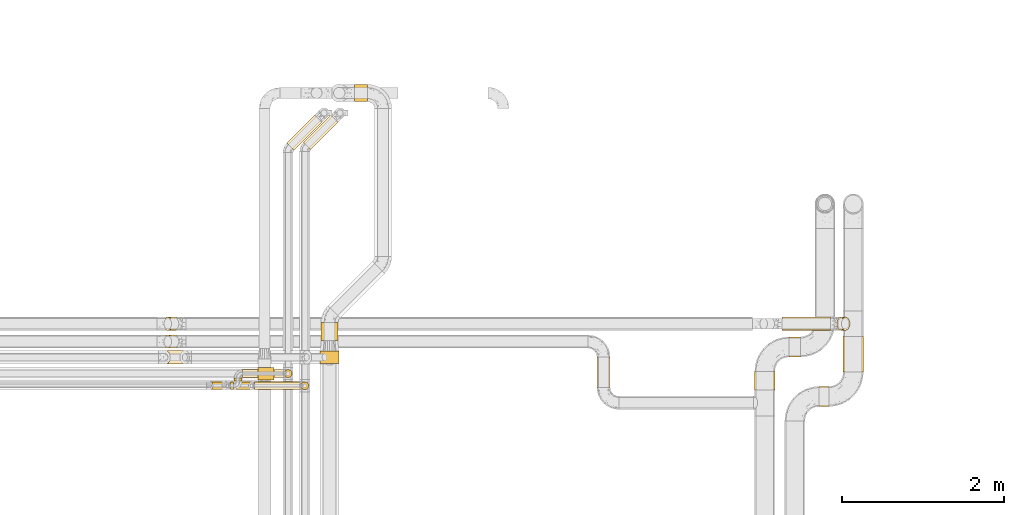
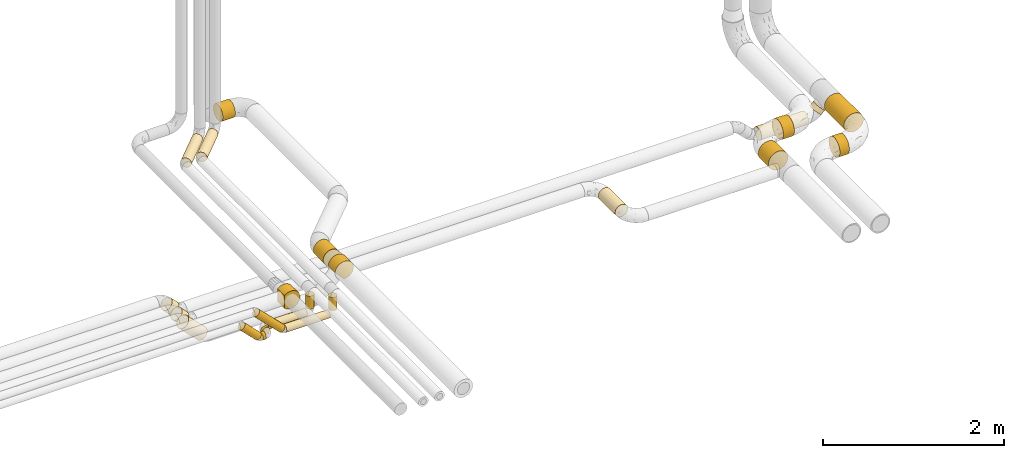
# One storey, part 4 of 93: 24 coverings.
"""IFC2X3 building model written with IfcOpenShell, lengths in millimetres."""

from ifc_helpers import new_model, entity, si_unit, converted_unit, derived_unit, direction, frame, frame_2d, origin, origin_2d_with_axis, place, context, subcontext, project, spatial, polyline, circle_curve, parameter, trimmed, segment, composite_curve, circle, outline, extrude, element, save


model = new_model("IFC2X3")

# Units and contexts
model_context = context("Model", 3, precision=0.01, world=origin(), true_north=direction((6.12303176911189e-17, 1.0)))
body_context = subcontext(model_context, "Body", "Model", "MODEL_VIEW")
ifc_project = project(units=[si_unit("LENGTHUNIT", "METRE", prefix="MILLI"), si_unit("AREAUNIT", "SQUARE_METRE"), si_unit("VOLUMEUNIT", "CUBIC_METRE"), converted_unit("PLANEANGLEUNIT", "DEGREE", entity("IfcRatioMeasure", 0.0174532925199433), si_unit("PLANEANGLEUNIT", "RADIAN"), dimensions=[0, 0, 0, 0, 0, 0, 0]), si_unit("MASSUNIT", "GRAM", prefix="KILO"), derived_unit("MASSDENSITYUNIT", [(si_unit("MASSUNIT", "GRAM", prefix="KILO"), 1), (si_unit("LENGTHUNIT", "METRE"), -3)]), derived_unit("MOMENTOFINERTIAUNIT", [(si_unit("LENGTHUNIT", "METRE"), 4)]), si_unit("TIMEUNIT", "SECOND"), si_unit("FREQUENCYUNIT", "HERTZ"), si_unit("THERMODYNAMICTEMPERATUREUNIT", "DEGREE_CELSIUS"), derived_unit("THERMALTRANSMITTANCEUNIT", [(si_unit("MASSUNIT", "GRAM", prefix="KILO"), 1), (si_unit("THERMODYNAMICTEMPERATUREUNIT", "KELVIN"), -1), (si_unit("TIMEUNIT", "SECOND"), -3)]), derived_unit("VOLUMETRICFLOWRATEUNIT", [(si_unit("LENGTHUNIT", "METRE"), 3), (si_unit("TIMEUNIT", "SECOND"), -1)]), derived_unit("MASSFLOWRATEUNIT", [(si_unit("MASSUNIT", "GRAM", prefix="KILO"), 1), (si_unit("TIMEUNIT", "SECOND"), -1)]), derived_unit("ROTATIONALFREQUENCYUNIT", [(si_unit("TIMEUNIT", "SECOND"), -1)]), si_unit("ELECTRICCURRENTUNIT", "AMPERE"), si_unit("ELECTRICVOLTAGEUNIT", "VOLT"), si_unit("POWERUNIT", "WATT"), si_unit("FORCEUNIT", "NEWTON", prefix="KILO"), si_unit("ILLUMINANCEUNIT", "LUX"), si_unit("LUMINOUSFLUXUNIT", "LUMEN"), si_unit("LUMINOUSINTENSITYUNIT", "CANDELA"), derived_unit("USERDEFINED", [(si_unit("MASSUNIT", "GRAM", prefix="KILO"), -1), (si_unit("LENGTHUNIT", "METRE"), -2), (si_unit("TIMEUNIT", "SECOND"), 3), (si_unit("LUMINOUSFLUXUNIT", "LUMEN"), 1)]), derived_unit("LINEARVELOCITYUNIT", [(si_unit("LENGTHUNIT", "METRE"), 1), (si_unit("TIMEUNIT", "SECOND"), -1)]), si_unit("PRESSUREUNIT", "PASCAL"), derived_unit("USERDEFINED", [(si_unit("LENGTHUNIT", "METRE"), -2), (si_unit("MASSUNIT", "GRAM", prefix="KILO"), 1), (si_unit("TIMEUNIT", "SECOND"), -2)]), derived_unit("LINEARFORCEUNIT", [(si_unit("MASSUNIT", "GRAM", prefix="KILO"), 1), (si_unit("LENGTHUNIT", "METRE"), 1), (si_unit("TIMEUNIT", "SECOND"), -2), (si_unit("LENGTHUNIT", "METRE"), -1)]), derived_unit("PLANARFORCEUNIT", [(si_unit("MASSUNIT", "GRAM", prefix="KILO"), 1), (si_unit("LENGTHUNIT", "METRE"), 1), (si_unit("TIMEUNIT", "SECOND"), -2), (si_unit("LENGTHUNIT", "METRE"), -2)])], contexts=[model_context])

# Site, building, storey
site_placement = place(None, origin())
site = spatial("IfcSite", under=ifc_project, at=site_placement, CompositionType="ELEMENT")
building_placement = place(site_placement, origin())
building = spatial("IfcBuilding", under=site, at=building_placement, CompositionType="ELEMENT")
storey_placement = place(building_placement, frame((0.0, 0.0, -4200.0)))
storey = spatial("IfcBuildingStorey", under=building, at=storey_placement, CompositionType="ELEMENT", Elevation=-4200.0)

# Coverings
covering_1_placement = place(storey_placement, frame((24871.2, 9268.64, 2891.9)))
element("IfcCovering", 1, at=covering_1_placement, inside=storey, Name=":ADSK_", ObjectType=":ADSK_", PredefinedType="INSULATION", context=body_context, shape_type="SweptSolid", body=[
    extrude(circle(Radius=106.5, at=origin_2d_with_axis()), frame((108.1, 0.0, 108.1), z_axis=(0.0, 1.0, 0.0), x_axis=(-1.0, 0.0, 0.0)), (0.0, 0.0, 1.0), 218.399081147116),
])
covering_2_placement = place(storey_placement, frame((25289.12, 12207.47, 2891.9)))
element("IfcCovering", 2, at=covering_2_placement, inside=storey, Name=":ADSK_", ObjectType=":ADSK_", PredefinedType="INSULATION", context=body_context, shape_type="SweptSolid", body=[
    extrude(circle(Radius=106.5, at=origin_2d_with_axis()), frame((0.0, 108.1, 108.1), z_axis=(1.0, 0.0, 0.0), x_axis=(0.0, -1.0, 0.0)), (0.0, 0.0, 1.0), 159.999999999968),
])
covering_3_placement = place(storey_placement, frame((28270.31, 8690.0, 2716.9)))
element("IfcCovering", 3, at=covering_3_placement, inside=storey, Name=":ADSK_", ObjectType=":ADSK_", PredefinedType="INSULATION", context=body_context, shape_type="SweptSolid", body=[
    extrude(circle(Radius=81.5, at=origin_2d_with_axis()), frame((83.1, 0.0, 83.1), z_axis=(0.0, 1.0, 0.0), x_axis=(1.0, 0.0, 0.0)), (0.0, 0.0, 1.0), 374.737441299343),
])
covering_4_placement = place(storey_placement, frame((24451.19, 11608.89, 2935.4)))
element("IfcCovering", 4, at=covering_4_placement, inside=storey, Name=":ADSK_", ObjectType=":ADSK_", PredefinedType="INSULATION", context=body_context, shape_type="SweptSolid", body=[
    extrude(circle(Radius=63.0, at=origin_2d_with_axis()), frame((46.14, 46.14, 64.6), z_axis=(0.707106781186561, 0.707106781186534, 0.0), x_axis=(-0.707106781186534, 0.707106781186561, 0.0)), (0.0, 0.0, 1.0), 486.862915010174),
])
covering_5_placement = place(storey_placement, frame((24417.45, 8810.55, 2757.0)))
element("IfcCovering", 5, at=covering_5_placement, inside=storey, Name=":ADSK_", ObjectType=":ADSK_", PredefinedType="INSULATION", context=body_context, shape_type="SweptSolid", body=[
    extrude(circle(Radius=49.0, at=origin_2d_with_axis()), frame((50.6, 50.6, 0.0)), (0.0, 0.0, 1.0), 176.000000000013),
])
covering_6_placement = place(storey_placement, frame((23756.66, 8660.55, 2649.4)))
element("IfcCovering", 6, at=covering_6_placement, inside=storey, Name=":ADSK_", ObjectType=":ADSK_", PredefinedType="INSULATION", context=body_context, shape_type="SweptSolid", body=[
    extrude(circle(Radius=49.0, at=origin_2d_with_axis()), frame((0.0, 50.6, 50.6), z_axis=(1.0, 0.0, 0.0), x_axis=(0.0, 1.0, 0.0)), (0.0, 0.0, 1.0), 39.389826944728),
])
covering_7_placement = place(storey_placement, frame((23470.65, 8660.55, 2680.45)))
element("IfcCovering", 7, at=covering_7_placement, inside=storey, Name=":ADSK_", ObjectType=":ADSK_", PredefinedType="INSULATION", context=body_context, shape_type="SweptSolid", body=[
    extrude(circle(Radius=49.0, at=origin_2d_with_axis()), frame((245.7, 50.6, 36.24), z_axis=(-0.70710678118655, 0.0, 0.707106781186545), x_axis=(0.0, -1.0, 0.0)), (0.0, 0.0, 1.0), 296.211111394568),
])
covering_8_placement = place(storey_placement, frame((23910.05, 8810.55, 2649.4)))
element("IfcCovering", 8, at=covering_8_placement, inside=storey, Name=":ADSK_", ObjectType=":ADSK_", PredefinedType="INSULATION", context=body_context, shape_type="SweptSolid", body=[
    extrude(circle(Radius=49.0, at=origin_2d_with_axis()), frame((0.0, 50.6, 50.6), z_axis=(1.0, 0.0, 0.0), x_axis=(0.0, -1.0, 0.0)), (0.0, 0.0, 1.0), 501.000000000012),
])
covering_9_placement = place(storey_placement, frame((23802.45, 8768.14, 2649.4)))
element("IfcCovering", 9, at=covering_9_placement, inside=storey, Name=":ADSK_", ObjectType=":ADSK_", PredefinedType="INSULATION", context=body_context, shape_type="SweptSolid", body=[
    extrude(circle(Radius=49.0, at=origin_2d_with_axis()), frame((50.6, 0.0, 50.6), z_axis=(0.0, 1.0, 0.0), x_axis=(1.0, 0.0, 0.0)), (0.0, 0.0, 1.0), 36.0000000000146),
])
covering_10_placement = place(storey_placement, frame((24657.6, 11618.89, 2935.4)))
element("IfcCovering", 10, at=covering_10_placement, inside=storey, Name=":ADSK_", ObjectType=":ADSK_", PredefinedType="INSULATION", context=body_context, shape_type="SweptSolid", body=[
    extrude(circle(Radius=63.0, at=origin_2d_with_axis()), frame((46.14, 46.14, 64.6), z_axis=(0.707106781186552, 0.707106781186543, 0.0), x_axis=(-0.707106781186543, 0.707106781186552, 0.0)), (0.0, 0.0, 1.0), 472.720779386446),
])
covering_11_placement = place(storey_placement, frame((24623.86, 8660.55, 2757.0)))
element("IfcCovering", 11, at=covering_11_placement, inside=storey, Name=":ADSK_", ObjectType=":ADSK_", PredefinedType="INSULATION", context=body_context, shape_type="SweptSolid", body=[
    extrude(circle(Radius=49.0, at=origin_2d_with_axis()), frame((50.6, 50.6, 0.0)), (0.0, 0.0, 1.0), 176.000000000013),
])
covering_12_placement = place(storey_placement, frame((23656.11, 8660.55, 2680.45)))
element("IfcCovering", 12, at=covering_12_placement, inside=storey, Name=":ADSK_", ObjectType=":ADSK_", PredefinedType="INSULATION", context=body_context, shape_type="SweptSolid", body=[
    extrude(circle(Radius=49.0, at=origin_2d_with_axis()), frame((361.65, 50.6, 36.24), z_axis=(-0.70710678118647, 0.0, 0.707106781186626), x_axis=(0.0, -1.0, 0.0)), (0.0, 0.0, 1.0), 460.201010126802),
])
covering_13_placement = place(storey_placement, frame((24058.07, 8660.55, 2649.4)))
element("IfcCovering", 13, at=covering_13_placement, inside=storey, Name=":ADSK_", ObjectType=":ADSK_", PredefinedType="INSULATION", context=body_context, shape_type="SweptSolid", body=[
    extrude(circle(Radius=49.0, at=origin_2d_with_axis()), frame((0.0, 50.6, 50.6), z_axis=(1.0, 0.0, 0.0), x_axis=(0.0, 1.0, 0.0)), (0.0, 0.0, 1.0), 559.389826944779),
])
covering_14_placement = place(storey_placement, frame((31009.78, 8452.66, 2673.9)))
element("IfcCovering", 14, at=covering_14_placement, inside=storey, Name=":ADSK_", ObjectType=":ADSK_", PredefinedType="INSULATION", context=body_context, shape_type="SweptSolid", body=[
    extrude(circle(Radius=124.5, at=origin_2d_with_axis()), frame((0.0, 126.1, 126.1), z_axis=(1.0, 0.0, 0.0), x_axis=(0.0, 1.0, 0.0)), (0.0, 0.0, 1.0), 120.218301649666),
])
covering_15_placement = place(storey_placement, frame((31303.9, 8878.76, 2673.9)))
element("IfcCovering", 15, at=covering_15_placement, inside=storey, Name=":ADSK_", ObjectType=":ADSK_", PredefinedType="INSULATION", context=body_context, shape_type="SweptSolid", body=[
    extrude(circle(Radius=124.5, at=origin_2d_with_axis()), frame((126.1, 0.0, 126.1), z_axis=(0.0, 1.0, 0.0), x_axis=(-1.0, 0.0, 0.0)), (0.0, 0.0, 1.0), 435.378639737444),
])
covering_16_placement = place(storey_placement, frame((22896.65, 8975.05, 2661.67)))
element("IfcCovering", 16, at=covering_16_placement, inside=storey, Name=":ADSK_", ObjectType=":ADSK_", PredefinedType="INSULATION", context=body_context, shape_type="SweptSolid", body=[
    extrude(circle(Radius=84.5, at=origin_2d_with_axis()), frame((61.35, 86.1, 300.18), z_axis=(0.707106781186547, 0.0, -0.707106781186548), x_axis=(0.0, -1.0, 0.0)), (0.0, 0.0, 1.0), 337.768480583875),
])
covering_17_placement = place(storey_placement, frame((22928.29, 9391.04, 2796.43)))
element("IfcCovering", 17, at=covering_17_placement, inside=storey, Name=":ADSK_", ObjectType=":ADSK_", PredefinedType="INSULATION", context=body_context, shape_type="SweptSolid", body=[
    extrude(circle(Radius=81.5, at=origin_2d_with_axis()), frame((59.22, 83.1, 147.93), z_axis=(0.707106781186542, 0.0, -0.707106781186553), x_axis=(0.0, -1.0, 0.0)), (0.0, 0.0, 1.0), 125.441558772784),
])
covering_18_placement = place(storey_placement, frame((22928.29, 9171.64, 2796.43)))
element("IfcCovering", 18, at=covering_18_placement, inside=storey, Name=":ADSK_", ObjectType=":ADSK_", PredefinedType="INSULATION", context=body_context, shape_type="SweptSolid", body=[
    extrude(circle(Radius=81.5, at=origin_2d_with_axis()), frame((147.93, 83.1, 59.22), z_axis=(-0.707106781186549, 0.0, 0.707106781186546), x_axis=(0.0, -1.0, 0.0)), (0.0, 0.0, 1.0), 125.441558772785),
])
covering_19_placement = place(storey_placement, frame((30213.69, 8660.0, 2673.9)))
element("IfcCovering", 19, at=covering_19_placement, inside=storey, Name=":ADSK_", ObjectType=":ADSK_", PredefinedType="INSULATION", context=body_context, shape_type="SweptSolid", body=[
    extrude(circle(Radius=124.5, at=origin_2d_with_axis()), frame((126.1, 0.0, 126.1), z_axis=(0.0, 1.0, 0.0), x_axis=(-1.0, 0.0, 0.0)), (0.0, 0.0, 1.0), 228.760416347831),
])
covering_20_placement = place(storey_placement, frame((30639.78, 9062.66, 2673.9)))
element("IfcCovering", 20, at=covering_20_placement, inside=storey, Name=":ADSK_", ObjectType=":ADSK_", PredefinedType="INSULATION", context=body_context, shape_type="SweptSolid", body=[
    extrude(circle(Radius=124.5, at=origin_2d_with_axis()), frame((0.0, 126.1, 126.1), z_axis=(1.0, 0.0, 0.0), x_axis=(0.0, 1.0, 0.0)), (0.0, 0.0, 1.0), 140.218301649687),
])
covering_21_placement = place(storey_placement, frame((30548.7, 9391.04, 2516.9)))
element("IfcCovering", 21, at=covering_21_placement, inside=storey, Name=":ADSK_", ObjectType=":ADSK_", PredefinedType="INSULATION", context=body_context, shape_type="SweptSolid", body=[
    extrude(circle(Radius=81.5, at=origin_2d_with_axis()), frame((0.0, 83.1, 83.1), z_axis=(1.0, 0.0, 0.0), x_axis=(0.0, -1.0, 0.0)), (0.0, 0.0, 1.0), 602.598846298237),
])
covering_22_placement = place(storey_placement, frame((31226.43, 9391.04, 2596.43)))
element("IfcCovering", 22, at=covering_22_placement, inside=storey, Name=":ADSK_", ObjectType=":ADSK_", PredefinedType="INSULATION", context=body_context, shape_type="SweptSolid", body=[
    extrude(circle(Radius=81.5, at=origin_2d_with_axis()), frame((59.22, 83.1, 59.22), z_axis=(0.707106781186553, 0.0, 0.707106781186542), x_axis=(0.0, -1.0, 0.0)), (0.0, 0.0, 1.0), 64.1421356237339),
])
covering_23_placement = place(storey_placement, frame((24095.2, 8782.48, 2881.66)))
element("IfcCovering", 23, at=covering_23_placement, inside=storey, Name=":ADSK_", ObjectType=":ADSK_", PredefinedType="INSULATION", context=body_context, shape_type="SweptSolid", body=[
    extrude(outline(composite_curve([segment(trimmed(circle_curve(frame_2d((30.36, 0.0), x_axis=(1.0, 0.0)), 117.5), [parameter(0.0)], [parameter(90.0)], True, "PARAMETER"), True, "CONTINUOUS"), segment(trimmed(circle_curve(frame_2d((30.36, 0.0), x_axis=(1.0, 0.0)), 117.5), [parameter(90.0)], [parameter(134.597956661475)], True, "PARAMETER"), True, "CONTINUOUS"), segment(polyline([(-52.14, 83.67), (-52.14, 28.28)]), True, "CONTINUOUS"), segment(polyline([(-52.14, 28.28), (-52.14, -28.28)]), True, "CONTINUOUS"), segment(polyline([(-52.14, -28.28), (-52.14, -83.67)]), True, "CONTINUOUS"), segment(trimmed(circle_curve(frame_2d((30.36, 0.0), x_axis=(1.0, 0.0)), 117.5), [parameter(225.402043338525)], [parameter(270.0)], True, "PARAMETER"), True, "CONTINUOUS"), segment(trimmed(circle_curve(frame_2d((30.36, 0.0), x_axis=(1.0, 0.0)), 117.5), [parameter(270.0)], [parameter(0.0)], True, "PARAMETER"), True, "CONTINUOUS")], self_intersect=False)), frame((53.74, 0.0, 119.1), z_axis=(0.0, 1.0, 0.0), x_axis=(1.0, 0.0, 0.0)), (0.0, 0.0, 1.0), 154.999999999995),
])
covering_24_placement = place(storey_placement, frame((24860.29, 8983.64, 2880.94)))
element("IfcCovering", 24, at=covering_24_placement, inside=storey, Name=":ADSK_", ObjectType=":ADSK_", PredefinedType="INSULATION", context=body_context, shape_type="SweptSolid", body=[
    extrude(outline(composite_curve([segment(trimmed(circle_curve(frame_2d((30.36, 0.0), x_axis=(1.0, 0.0)), 117.5), [parameter(2.03555499613665e-13)], [parameter(90.0000000000002)], True, "PARAMETER"), True, "CONTINUOUS"), segment(trimmed(circle_curve(frame_2d((30.36, 0.0), x_axis=(1.0, 0.0)), 117.5), [parameter(90.0000000000005)], [parameter(134.597956661477)], True, "PARAMETER"), True, "CONTINUOUS"), segment(polyline([(-52.14, 83.67), (-52.14, 28.28)]), True, "CONTINUOUS"), segment(polyline([(-52.14, 28.28), (-52.14, -28.28)]), True, "CONTINUOUS"), segment(polyline([(-52.14, -28.28), (-52.14, -83.67)]), True, "CONTINUOUS"), segment(trimmed(circle_curve(frame_2d((30.36, 0.0), x_axis=(1.0, 0.0)), 117.5), [parameter(225.402043338523)], [parameter(270.0)], True, "PARAMETER"), True, "CONTINUOUS"), segment(trimmed(circle_curve(frame_2d((30.36, 0.0), x_axis=(1.0, 0.0)), 117.5), [parameter(270.0)], [parameter(2.03555499613665e-13)], True, "PARAMETER"), True, "CONTINUOUS")], self_intersect=False)), frame((96.86, 0.0, 98.29), z_axis=(0.0, 1.0, 0.0), x_axis=(0.729493626406701, 0.0, 0.683987608829283)), (0.0, 0.0, 1.0), 154.999999999995),
])

save(model, "model.ifc")
